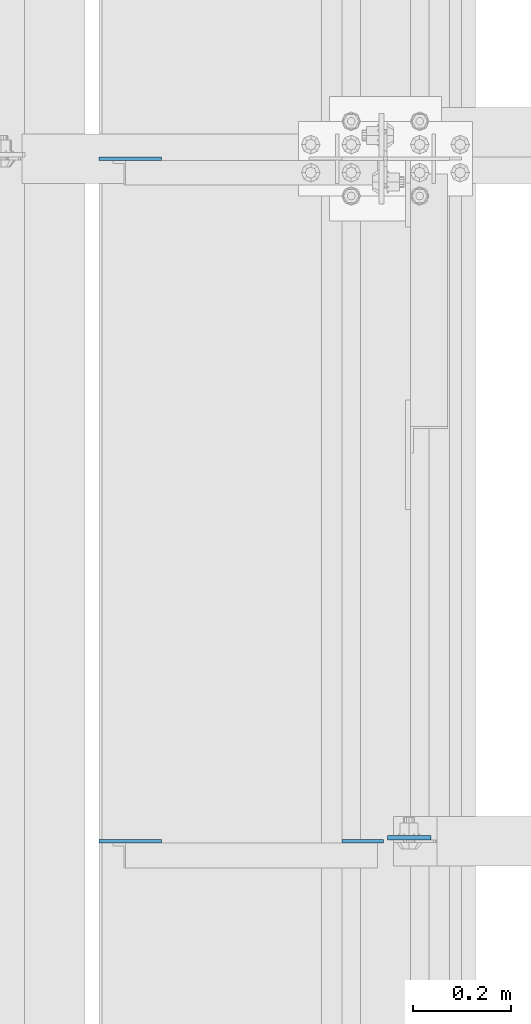
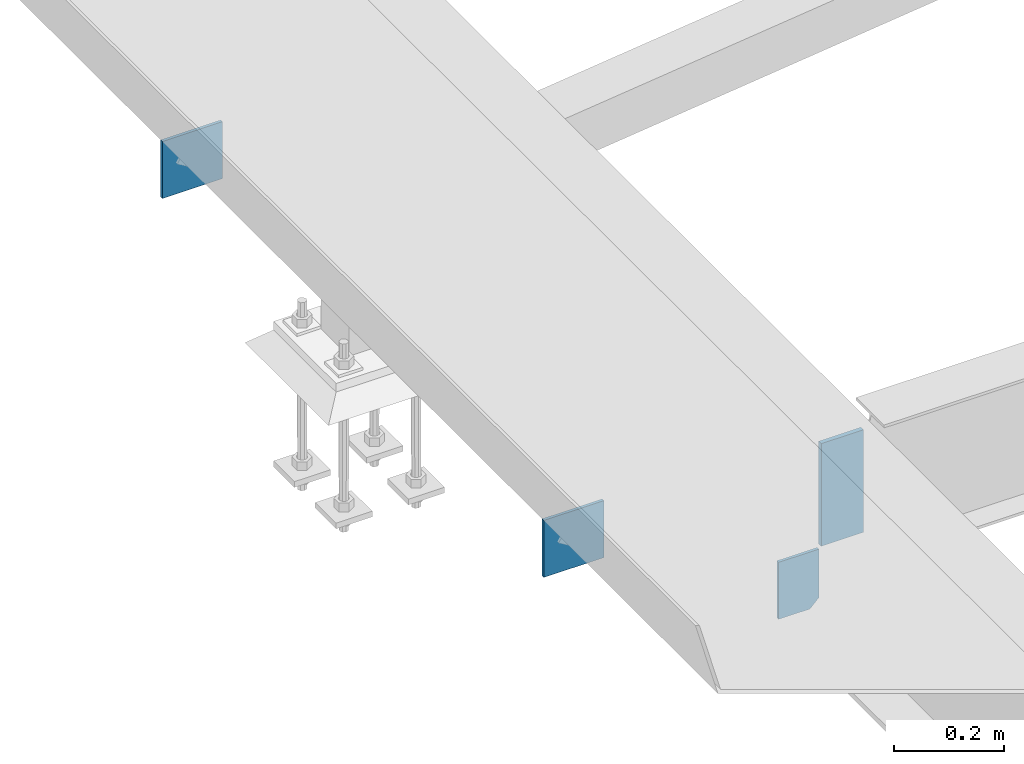
# One storey, part 3232 of 3843: 4 plates, 1 element without a shape of its own.
"""IFC2X3 building model written with IfcOpenShell, lengths in millimetres."""

import ifcopenshell
import ifcopenshell.guid

model = None  # the IFC model being written
_history = None  # IfcOwnerHistory: only IFC2X3 demands one
_inside = {}  # id of a spatial element -> (the spatial element, [elements in it])
_under = {}  # id of a project, library or spatial element -> (it, [spatial elements below it])
_declared = {}  # id of a project -> (the project, [libraries it declares])
_typed = {}  # id of a type object -> (the type object, [elements of that type])
_made_of = {}  # id of a material, layer set ... -> (it, [elements and type objects made of it])


def new_model(schema):
    """Start an empty IFC model of exactly this schema.

    Asked for "IFC4X3", IfcOpenShell would pick the latest addendum, in which some entities
    have other attributes; the version numbers below select the first issue.
    IFC2X3 requires an IfcOwnerHistory on every rooted entity: one is made here for all.
    """
    global model, _history
    if schema == "IFC4X3":
        model = ifcopenshell.file(schema_version=(4, 3, 0, 0))
    else:
        model = ifcopenshell.file(schema=schema)
    _inside.clear()
    _under.clear()
    _declared.clear()
    _typed.clear()
    _made_of.clear()
    _history = None
    if model.schema == "IFC2X3":
        org = make("IfcOrganization", Name="unknown")
        user = make(
            "IfcPersonAndOrganization",
            ThePerson=make("IfcPerson", FamilyName="unknown"),
            TheOrganization=org,
        )
        app = make(
            "IfcApplication",
            ApplicationDeveloper=org,
            Version="unknown",
            ApplicationFullName="unknown",
            ApplicationIdentifier="unknown",
        )
        _history = make(
            "IfcOwnerHistory",
            OwningUser=user,
            OwningApplication=app,
            ChangeAction="ADDED",
            CreationDate=0,
        )
    return model


def make(cls, **values):
    """One entity of the class cls with the attributes given. An attribute that is None is left unset."""
    return model.create_entity(
        cls, **{name: value for name, value in values.items() if value is not None}
    )


def rooted(cls, **values):
    """An entity with a GlobalId (a new one), such as an element, a storey or a relation."""
    return make(cls, GlobalId=ifcopenshell.guid.new(), OwnerHistory=_history, **values)


def si_unit(unit_type, name, prefix=None):
    """IfcSIUnit, for example si_unit("LENGTHUNIT", "METRE", prefix="MILLI")."""
    return make("IfcSIUnit", UnitType=unit_type, Prefix=prefix, Name=name)


def assignment(units):
    """IfcUnitAssignment: the units of a project."""
    return None if units is None else make("IfcUnitAssignment", Units=units)


def point(xyz):
    """IfcCartesianPoint."""
    return None if xyz is None else make("IfcCartesianPoint", Coordinates=xyz)


def direction(xyz):
    """IfcDirection."""
    return None if xyz is None else make("IfcDirection", DirectionRatios=xyz)


def frame(location, z_axis=None, x_axis=None):
    """IfcAxis2Placement3D, a coordinate frame: its origin and axes. An axis left out is left unset."""
    return make(
        "IfcAxis2Placement3D",
        Location=point(location),
        Axis=direction(z_axis),
        RefDirection=direction(x_axis),
    )


def origin_with_axes():
    """The frame at (0, 0, 0) with the z axis (0, 0, 1) and the x axis (1, 0, 0) written out."""
    return frame((0.0, 0.0, 0.0), z_axis=(0.0, 0.0, 1.0), x_axis=(1.0, 0.0, 0.0))


def place(relative_to, where):
    """IfcLocalPlacement: puts the frame where relative to a parent placement (None: the world)."""
    return make(
        "IfcLocalPlacement", PlacementRelTo=relative_to, RelativePlacement=where
    )


def context(
    kind, dimensions, precision=None, world=None, true_north=None, identifier=None
):
    """IfcGeometricRepresentationContext, for example the 3D "Model" context."""
    return make(
        "IfcGeometricRepresentationContext",
        ContextIdentifier=identifier,
        ContextType=kind,
        CoordinateSpaceDimension=dimensions,
        Precision=precision,
        WorldCoordinateSystem=world,
        TrueNorth=true_north,
    )


def subcontext(parent, identifier, kind, view, scale=None):
    """IfcGeometricRepresentationSubContext, for example "Body" below "Model"."""
    return make(
        "IfcGeometricRepresentationSubContext",
        ContextIdentifier=identifier,
        ContextType=kind,
        ParentContext=parent,
        TargetScale=scale,
        TargetView=view,
    )


def project(units=None, contexts=None):
    """IfcProject with its units and contexts."""
    return rooted(
        "IfcProject",
        Name="project",
        RepresentationContexts=contexts,
        UnitsInContext=assignment(units),
    )


def spatial(cls, under=None, at=None, **own):
    """A site, building, storey or space (cls), placed at a placement, below another one or the project."""
    s = rooted(cls, ObjectPlacement=at, **own)
    if under is not None:
        _under.setdefault(under.id(), (under, []))[1].append(s)
    return s


def faces_of(points, faces, orient=None, outer=None):
    """IfcFace entities. A face is a list of loops; a loop is a list of indices into points, from 0.

    orient and outer hold one flag for each loop. By default every Orientation is true, the
    first loop of a face is its IfcFaceOuterBound and the others are IfcFaceBound.
    """
    made = []
    for i, loops in enumerate(faces):
        bounds = []
        for j, loop in enumerate(loops):
            is_outer = j == 0 if outer is None else outer[i][j]
            bounds.append(
                make(
                    "IfcFaceOuterBound" if is_outer else "IfcFaceBound",
                    Bound=make("IfcPolyLoop", Polygon=[points[k] for k in loop]),
                    Orientation=True if orient is None else orient[i][j],
                )
            )
        made.append(make("IfcFace", Bounds=bounds))
    return made


def faceted_brep(points, faces, orient=None, outer=None, voids=None):
    """IfcFacetedBrep: a solid bounded by flat faces; with voids (closed shells), ...WithVoids."""
    shared = [point(p) for p in points]
    hull = make("IfcClosedShell", CfsFaces=faces_of(shared, faces, orient, outer))
    if voids is None:
        return make("IfcFacetedBrep", Outer=hull)
    return make(
        "IfcFacetedBrepWithVoids",
        Outer=hull,
        Voids=[
            make(cls, CfsFaces=faces_of(shared, fs, o, b)) for cls, fs, o, b in voids
        ],
    )


def shape(context_of_items, identifier, shape_type, items):
    """IfcShapeRepresentation: the items that make up one representation, for example the "Body"."""
    return make(
        "IfcShapeRepresentation",
        ContextOfItems=context_of_items,
        RepresentationIdentifier=identifier,
        RepresentationType=shape_type,
        Items=items,
    )


def material(Name=None, Category=None):
    """IfcMaterial."""
    return make("IfcMaterial", Name=Name, Category=Category)


def made_of(thing, what):
    """Note that an element or type object is made of a material, layer set ...; save() writes the relation."""
    if what is not None:
        _made_of.setdefault(what.id(), (what, []))[1].append(thing)
    return thing


def type_object(cls, material=None, **own):
    """A type object (cls), such as IfcWallType, which elements share."""
    return made_of(rooted(cls, **own), material)


def element(
    cls,
    number,
    at=None,
    inside=None,
    cuts=None,
    type_object=None,
    material=None,
    context=None,
    identifier="Body",
    shape_type=None,
    held_by="IfcProductDefinitionShape",
    body=None,
    shapes=None,
    **own,
):
    """One element of the class cls, such as IfcWall. Its Tag is "e" and its number.

    at: its placement. inside: the storey or other place that contains it. cuts: it is an
    opening in that element (IfcRelVoidsElement). A single representation is given by context,
    identifier, shape_type and body (its items); several are given by shapes. held_by: the class
    of the entity that holds the representations. save() writes the other relations.
    """
    e = rooted(cls, Tag="e%d" % number, ObjectPlacement=at, **own)
    if body is not None:
        shapes = [shape(context, identifier, shape_type, body)]
    if shapes is not None:
        e.Representation = make(held_by, Representations=shapes)
    if inside is not None:
        _inside.setdefault(inside.id(), (inside, []))[1].append(e)
    if cuts is not None:
        rooted(
            "IfcRelVoidsElement", RelatingBuildingElement=cuts, RelatedOpeningElement=e
        )
    if type_object is not None:
        _typed.setdefault(type_object.id(), (type_object, []))[1].append(e)
    return made_of(e, material)


def aggregate(whole, parts):
    """IfcRelAggregates: a whole, such as a stair, and the parts it consists of."""
    return rooted("IfcRelAggregates", RelatingObject=whole, RelatedObjects=parts)


def save(model, path):
    """Write the relations noted so far, then the file.

    IfcRelAggregates (storeys below a building ...), IfcRelContainedInSpatialStructure (elements
    in a storey), IfcRelDefinesByType, IfcRelAssociatesMaterial and IfcRelDeclares: one each for
    every whole, place, type object, material and project.
    """
    for whole, parts in _under.values():
        aggregate(whole, parts)
    for where, things in _inside.values():
        rooted(
            "IfcRelContainedInSpatialStructure",
            RelatedElements=things,
            RelatingStructure=where,
        )
    for kind, things in _typed.values():
        rooted("IfcRelDefinesByType", RelatedObjects=things, RelatingType=kind)
    for what, things in _made_of.values():
        rooted("IfcRelAssociatesMaterial", RelatedObjects=things, RelatingMaterial=what)
    for by, libraries in _declared.values():
        rooted("IfcRelDeclares", RelatingContext=by, RelatedDefinitions=libraries)
    model.write(path)


model = new_model("IFC2X3")

# Units and contexts
model_context = context("Model", 3, precision=1e-05, world=origin_with_axes())
body_context = subcontext(model_context, "Body", "Model", "MODEL_VIEW")
ifc_project = project(units=[si_unit("LENGTHUNIT", "METRE", prefix="MILLI"), si_unit("AREAUNIT", "SQUARE_METRE"), si_unit("VOLUMEUNIT", "CUBIC_METRE"), si_unit("MASSUNIT", "GRAM", prefix="KILO"), si_unit("TIMEUNIT", "SECOND"), si_unit("PLANEANGLEUNIT", "RADIAN"), si_unit("SOLIDANGLEUNIT", "STERADIAN"), si_unit("THERMODYNAMICTEMPERATUREUNIT", "DEGREE_CELSIUS"), si_unit("LUMINOUSINTENSITYUNIT", "LUMEN")], contexts=[model_context])

# Site, building, storey
site_placement = place(None, origin_with_axes())
site = spatial("IfcSite", under=ifc_project, at=site_placement, CompositionType="ELEMENT")
building_placement = place(site_placement, origin_with_axes())
building = spatial("IfcBuilding", under=site, at=building_placement, Name="Undefined", CompositionType="ELEMENT")
storey_placement = place(building_placement, origin_with_axes())
storey = spatial("IfcBuildingStorey", under=building, at=storey_placement, Name="Undefined", CompositionType="ELEMENT", Elevation=0.0)

# Assembly, plates
assembly_placement = place(storey_placement, origin_with_axes())
assembly = element("IfcElementAssembly", 1, at=assembly_placement, inside=storey, Name="BEAM", AssemblyPlace="NOTDEFINED", PredefinedType="RIGID_FRAME")
ifc_material = material(Name="STEEL/A572-50")
plate_type_1 = type_object("IfcPlateType", PredefinedType="NOTDEFINED")
plate_1_placement = place(assembly_placement, frame((36579.96875, 44994.710938, 33997.9), z_axis=(1.0, 0.0, 0.0), x_axis=(0.0, 0.0, -1.0)))
plate_1 = element("IfcPlate", 2, at=plate_1_placement, type_object=plate_type_1, material=ifc_material, Name="PLATE", context=body_context, shape_type="Brep", body=[
    faceted_brep([(0.0, -4.76249999999709, 0.0), (0.0, -4.76249999999709, 88.9000015258789), (0.0, 4.76249999999709, 88.9000015258789), (0.0, 4.76249999999709, 0.0), (228.600006102781, -4.7625000004191, 88.9000015257589), (228.600006102781, 4.76249999954598, 88.9000015257443), (228.600006103079, -4.7625000004482, 7.27595761418343e-12), (228.600006103079, 4.76249999954598, -7.27595761418343e-12)], [[[0, 1, 2, 3]], [[1, 4, 5, 2]], [[4, 6, 7, 5]], [[6, 0, 3, 7]], [[5, 7, 3, 2]], [[6, 4, 1, 0]]]),
])
plate_type_2 = type_object("IfcPlateType", PredefinedType="NOTDEFINED")
plate_2_placement = place(assembly_placement, frame((35991.8000305176, 44987.5671880001, 33909.0000061035), z_axis=(0.0, 0.0, 1.0), x_axis=(1.0, 0.0, 0.0)))
plate_2 = element("IfcPlate", 3, at=plate_2_placement, type_object=plate_type_2, material=ifc_material, Name="PLATE", context=body_context, shape_type="Brep", body=[
    faceted_brep([(0.0, -3.17499999999927, 0.0), (-6.10351708019152e-06, -3.17500000000291, 126.999993896483), (-6.10351708019152e-06, 3.17500000000291, 126.999993896483), (0.0, 3.17499999999927, 0.0), (127.0, -3.17500000000291, 127.0), (127.0, 3.17500000000291, 127.0), (127.0, -3.17500000000291, 0.0), (127.0, 3.17500000000291, 0.0)], [[[0, 1, 2, 3]], [[1, 4, 5, 2]], [[4, 6, 7, 5]], [[6, 0, 3, 7]], [[5, 7, 3, 2]], [[6, 4, 1, 0]]]),
])
plate_3_placement = place(assembly_placement, frame((35991.8000305176, 46380.3007820001, 33909.0000061035), z_axis=(0.0, 0.0, 1.0), x_axis=(1.0, 0.0, 0.0)))
plate_3 = element("IfcPlate", 4, at=plate_3_placement, type_object=plate_type_2, material=ifc_material, Name="PLATE", context=body_context, shape_type="Brep", body=[
    faceted_brep([(0.0, -3.17499999999927, 0.0), (-6.10351708019152e-06, -3.17500000000291, 126.999993896483), (-6.10351708019152e-06, 3.17500000000291, 126.999993896483), (0.0, 3.17499999999927, 0.0), (127.0, -3.17500000000291, 127.0), (127.0, 3.17500000000291, 127.0), (127.0, -3.17500000000291, 0.0), (127.0, 3.17500000000291, 0.0)], [[[0, 1, 2, 3]], [[1, 4, 5, 2]], [[4, 6, 7, 5]], [[6, 0, 3, 7]], [[5, 7, 3, 2]], [[6, 4, 1, 0]]]),
])
plate_type_3 = type_object("IfcPlateType", PredefinedType="NOTDEFINED")
plate_4_placement = place(assembly_placement, frame((36572.0312591215, 44987.567188, 33769.3), z_axis=(0.0, 0.0, -1.0), x_axis=(-1.0, 0.0, 0.0)))
plate_4 = element("IfcPlate", 5, at=plate_4_placement, type_object=plate_type_3, material=ifc_material, Name="PLATE", context=body_context, shape_type="Brep", body=[
    faceted_brep([(0.0, -3.17499999999927, 0.0), (0.0, -3.17500000000291, 107.950000000004), (0.0, 3.17500000000291, 107.950000000004), (0.0, 3.17499999999927, 0.0), (19.0500000000029, -3.17500000000291, 127.0), (19.0500000000029, 3.17500000000291, 127.0), (84.9312591264534, -3.17500000000291, 126.999993896701), (84.9312591264534, 3.17500000000291, 126.999993896701), (84.9312500000015, -3.17500000000291, 2.18278728425503e-10), (84.9312500000015, 3.17500000000291, 2.18278728425503e-10)], [[[0, 1, 2, 3]], [[1, 4, 5, 2]], [[4, 6, 7, 5]], [[6, 8, 9, 7]], [[8, 0, 3, 9]], [[5, 7, 9, 3, 2]], [[8, 6, 4, 1, 0]]]),
])
aggregate(assembly, [plate_4, plate_2, plate_3, plate_1])

save(model, "model.ifc")
